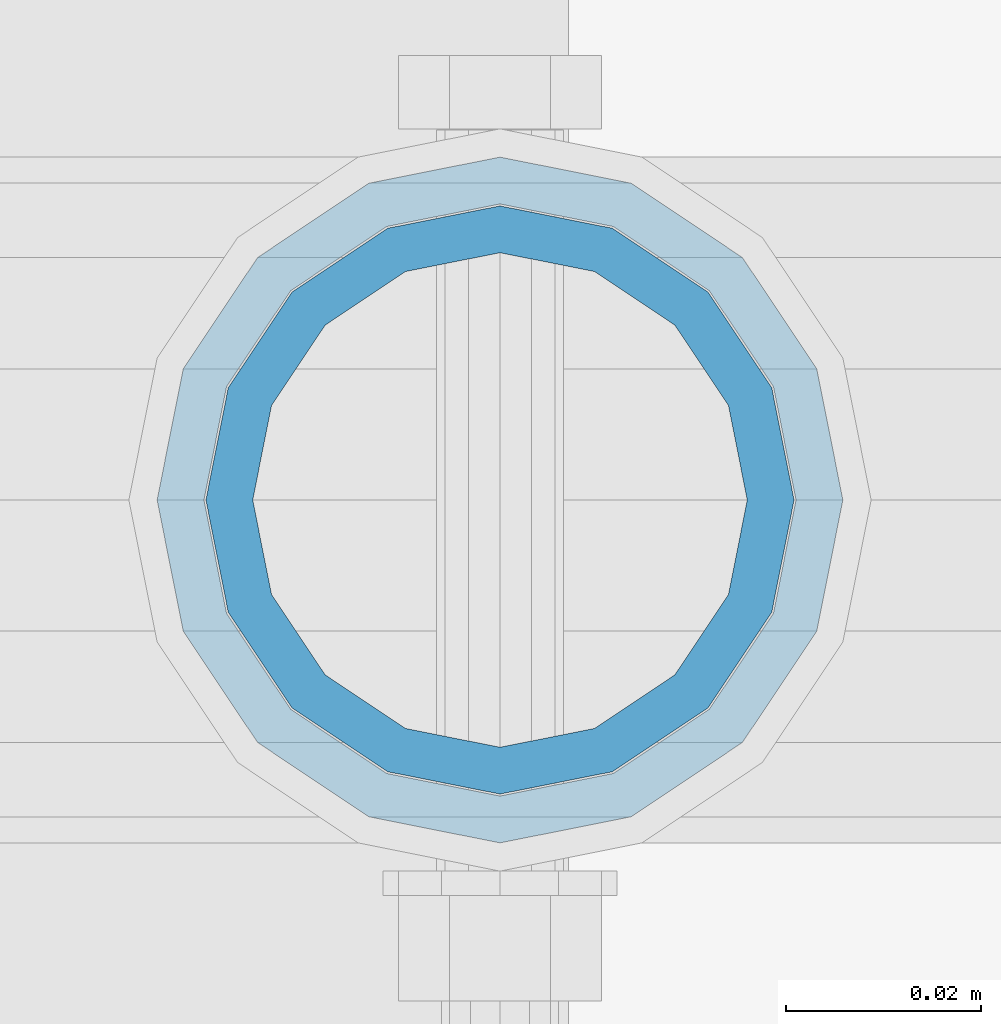
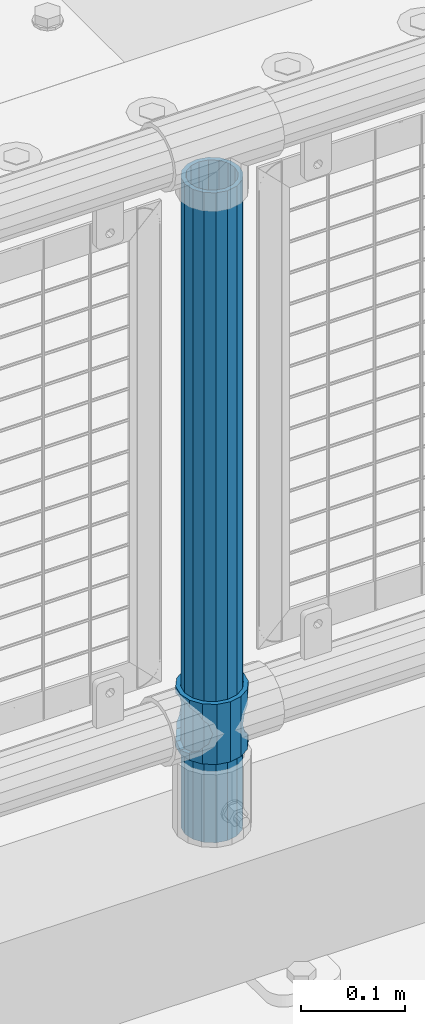
# One storey, part 82 of 240: 2 columns.
"""IFC2X3 building model written with IfcOpenShell, lengths in millimetres."""

from ifc_helpers import new_model, si_unit, frame, origin_with_axes, place, context, subcontext, project, spatial, faceted_brep, material, type_object, element, save


model = new_model("IFC2X3")

# Units and contexts
model_context = context("Model", 3, precision=1e-05, world=origin_with_axes())
body_context = subcontext(model_context, "Body", "Model", "MODEL_VIEW")
ifc_project = project(units=[si_unit("LENGTHUNIT", "METRE", prefix="MILLI"), si_unit("AREAUNIT", "SQUARE_METRE"), si_unit("VOLUMEUNIT", "CUBIC_METRE"), si_unit("MASSUNIT", "GRAM", prefix="KILO"), si_unit("TIMEUNIT", "SECOND"), si_unit("PLANEANGLEUNIT", "RADIAN"), si_unit("SOLIDANGLEUNIT", "STERADIAN"), si_unit("THERMODYNAMICTEMPERATUREUNIT", "DEGREE_CELSIUS"), si_unit("LUMINOUSINTENSITYUNIT", "LUMEN")], contexts=[model_context])

# Site, building, storey
site_placement = place(None, origin_with_axes())
site = spatial("IfcSite", under=ifc_project, at=site_placement, CompositionType="ELEMENT")
building_placement = place(site_placement, origin_with_axes())
building = spatial("IfcBuilding", under=site, at=building_placement, Name="Standard", CompositionType="ELEMENT")
storey_placement = place(building_placement, origin_with_axes())
storey = spatial("IfcBuildingStorey", under=building, at=storey_placement, Name="Undefined", CompositionType="ELEMENT", Elevation=0.0)

# Columns
ifc_material_1 = material(Name="Misc_Undefined")
column_type_1 = type_object("IfcColumnType", PredefinedType="NOTDEFINED")
column_1_placement = place(storey_placement, frame((49703.0, 34664.5, 263.02), z_axis=(-1.0, 0.0, 0.0), x_axis=(0.0, 0.0, 1.0)))
element("IfcColumn", 1, at=column_1_placement, inside=storey, type_object=column_type_1, material=ifc_material_1, context=body_context, shape_type="Brep", body=[
    faceted_brep([(56.6106908090114, 21.4606908090136, -21.4606908090136), (56.6106908090114, 21.4606908090136, -27.1226768591077), (61.9623795176703, 13.4513226476338, -32.4743655677739), (63.1897438117172, 11.6144421722784, -32.8397438117172), (63.1897438117172, 11.6144421722784, -28.0397438117143), (46.7644421722801, 28.0397438117143, -11.6144421722784), (46.7644421722801, 28.0397438117143, -20.0882031229849), (51.5310424079941, 24.8548033587067, -24.8548033587067), (35.1500000000015, 30.35, 0.0), (35.1499999999996, 30.3499999999985, -16.6306603983685), (23.5355578277192, 28.0397438117143, -11.6144421722784), (23.5355578277192, 28.0397438117143, -20.0882031229849), (13.6893091909879, 21.4606908090136, -21.4606908090136), (13.6893091909879, 21.4606908090136, -27.1226768591077), (18.7689575919921, 24.8548033587067, -24.8548033587067), (7.11025618828211, 11.6144421722784, -28.0397438117143), (7.11025618828211, 11.6144421722784, -32.8397438117172), (8.33762048232893, 13.4513226476338, -32.4743655677739), (4.79999999999961, 0.0, -30.3499999999985), (4.79999999999961, 0.0, -35.1500000000015), (7.11025618828211, -11.6144421722784, -28.0397438117143), (7.11025618828211, -11.6144421722784, -32.8397438117245), (13.6893091909879, -21.4606908090136, -21.4606908090136), (13.6893091909879, -21.4606908090136, -27.1226768591223), (8.33762048232455, -13.4513226476338, -32.4743655677739), (23.5355578277191, -28.0397438117143, -11.6144421722784), (23.5355578277191, -28.0397438117143, -20.0882031229994), (18.7689575919987, -24.8548033587067, -24.8548033587067), (35.1500000000015, -30.35, 0.0), (35.1499999999996, -30.3499999999985, -16.6306603983758), (46.7644421722801, -28.0397438117143, -11.6144421722784), (46.7644421722801, -28.0397438117143, -20.0882031229994), (56.6106908090114, -21.4606908090136, -21.4606908090136), (56.6106908090114, -21.4606908090136, -27.1226768591223), (51.5310424080006, -24.8548033587067, -24.8548033587067), (63.1897438117172, -11.6144421722784, -28.0397438117143), (63.1897438117172, -11.6144421722784, -32.8397438117245), (61.9623795176703, -13.4513226476338, -32.4743655677739), (65.4999999999997, 0.0, -30.3499999999985), (65.4999999999997, 0.0, -35.1500000000015), (0.0, -28.0397438117143, -11.6144421722784), (0.0, -30.3499999999985, 0.0), (0.0, -21.4606908090136, -21.4606908090136), (0.0, -11.6144421722784, -28.0397438117143), (0.0, 0.0, -30.3499999999985), (0.0, 11.6144421722784, -28.0397438117143), (0.0, 21.4606908090136, -21.4606908090136), (0.0, 28.0397438117143, -11.6144421722784), (0.0, 30.3499999999985, 0.0), (0.0, 28.0397438117143, 11.6144421722784), (23.5355578277192, 28.0397438117143, 11.6144421722784), (0.0, 21.4606908090136, 21.4606908090136), (13.6893091909879, 21.4606908090136, 21.4606908090136), (0.0, 11.6144421722784, 28.0397438117143), (7.11025618828211, 11.6144421722784, 28.0397438117143), (0.0, 0.0, 30.3499999999985), (4.79999999999961, 0.0, 30.3499999999985), (0.0, -11.6144421722784, 28.0397438117143), (7.11025618828205, -11.6144421722784, 28.0397438117143), (0.0, -21.4606908090136, 21.4606908090136), (13.6893091909879, -21.4606908090136, 21.4606908090136), (0.0, -28.0397438117143, 11.6144421722784), (23.5355578277191, -28.0397438117143, 11.6144421722784), (0.0, -32.4743655677739, 13.4513226476338), (0.0, -35.1500000000015, 0.0), (70.2999999999993, -35.1500000000015, 0.0), (70.2999999999993, -32.4743655677739, 13.4513226476338), (0.0, 13.4513226476338, -32.4743655677739), (0.0, 24.8548033587067, -24.8548033587067), (0.0, 0.0, -35.1500000000015), (0.0, -13.4513226476338, -32.4743655677739), (0.0, -24.8548033587067, -24.8548033587067), (0.0, -24.8548033587067, 24.8548033587067), (0.0, -13.4513226476338, 32.4743655677739), (0.0, 0.0, 35.1500000000015), (0.0, 13.4513226476338, 32.4743655677739), (0.0, 24.8548033587067, 24.8548033587067), (0.0, 32.4743655677739, 13.4513226476338), (0.0, 35.1500000000015, 0.0), (0.0, 32.4743655677739, -13.4513226476338), (0.0, -32.4743655677739, -13.4513226476338), (70.2999999999993, 32.4743655677739, 13.4513226476338), (70.2999999999993, 35.1500000000015, 0.0), (70.2999999999993, 32.4743655677739, -13.4513226476338), (70.2999999999993, 24.8548033587067, -24.8548033587067), (70.2999999999993, 13.4513226476338, -32.4743655677739), (70.2999999999993, 0.0, -35.1500000000015), (70.2999999999993, -13.4513226476338, -32.4743655677739), (70.2999999999993, -24.8548033587067, -24.8548033587067), (70.2999999999993, -32.4743655677739, -13.4513226476338), (70.2999999999993, 28.0397438117143, 11.6144421722784), (70.2999999999993, 21.4606908090136, 21.4606908090136), (56.6106908090114, 21.4606908090136, 21.4606908090136), (46.7644421722801, 28.0397438117143, 11.6144421722784), (70.2999999999993, 11.6144421722784, 28.0397438117143), (63.1897438117172, 11.6144421722784, 28.0397438117143), (70.2999999999993, 0.0, 30.3499999999985), (65.4999999999997, 0.0, 30.3499999999985), (70.2999999999993, -11.6144421722784, 28.0397438117143), (63.1897438117172, -11.6144421722784, 28.0397438117143), (70.2999999999993, -21.4606908090136, 21.4606908090136), (56.6106908090114, -21.4606908090136, 21.4606908090136), (70.2999999999993, -28.0397438117143, 11.6144421722784), (46.7644421722801, -28.0397438117143, 11.6144421722784), (70.2999999999993, -11.6144421722784, -28.0397438117143), (70.2999999999993, 0.0, -30.3499999999985), (70.2999999999993, -21.4606908090136, -21.4606908090136), (70.2999999999993, -28.0397438117143, -11.6144421722784), (70.2999999999993, -30.3499999999985, 0.0), (70.2999999999993, 24.8548033587067, 24.8548033587067), (70.2999999999993, 13.4513226476338, 32.4743655677739), (70.2999999999993, 0.0, 35.1500000000015), (70.2999999999993, -13.4513226476338, 32.4743655677739), (70.2999999999993, -24.8548033587067, 24.8548033587067), (70.2999999999993, 30.3499999999985, 0.0), (70.2999999999993, 28.0397438117143, -11.6144421722784), (70.2999999999993, 21.4606908090136, -21.4606908090136), (70.2999999999993, 11.6144421722784, -28.0397438117143), (61.9623795176742, 13.4513226476338, 32.4743655677739), (51.5310424079941, 24.8548033587067, 24.8548033587067), (56.6106908090114, 21.4606908090136, 27.1226768591077), (65.4999999999997, 0.0, 35.1500000000015), (63.1897438117172, 11.6144421722784, 32.8397438117172), (63.1897438117172, -11.6144421722784, 32.8397438117172), (61.9623795176698, -13.4513226476338, 32.4743655677739), (56.6106908090114, -21.4606908090136, 27.1226768591005), (51.5310424080006, -24.8548033587067, 24.8548033587067), (18.7689575919987, -24.8548033587067, 24.8548033587067), (46.7644421722801, -28.0397438117143, 20.0882031229994), (35.1499999999996, -30.3499999999985, 16.6306603983758), (23.5355578277191, -28.0397438117143, 20.0882031229994), (8.33762048232506, -13.4513226476338, 32.4743655677739), (13.6893091909879, -21.4606908090136, 27.1226768591005), (4.79999999999961, 0.0, 35.1500000000015), (7.11025618828205, -11.6144421722784, 32.8397438117172), (7.11025618828211, 11.6144421722784, 32.8397438117172), (8.33762048232506, 13.4513226476338, 32.4743655677739), (13.6893091909879, 21.4606908090136, 27.1226768591077), (18.7689575919856, 24.8548033587067, 24.8548033587067), (23.5355578277192, 28.0397438117143, 20.0882031229994), (35.1499999999996, 30.3499999999985, 16.6306603983758), (46.7644421722801, 28.0397438117143, 20.0882031229994)], [[[0, 1, 2, 3, 4]], [[5, 6, 7, 1, 0]], [[8, 9, 6, 5]], [[10, 11, 9, 8]], [[12, 13, 14, 11, 10]], [[15, 16, 17, 13, 12]], [[18, 19, 16, 15]], [[20, 21, 19, 18]], [[22, 23, 24, 21, 20]], [[25, 26, 27, 23, 22]], [[28, 29, 26, 25]], [[30, 31, 29, 28]], [[32, 33, 34, 31, 30]], [[35, 36, 37, 33, 32]], [[38, 39, 36, 35]], [[4, 3, 39, 38]], [[40, 41, 28, 25]], [[42, 40, 25, 22]], [[43, 42, 22, 20]], [[44, 43, 20, 18]], [[45, 44, 18, 15]], [[46, 45, 15, 12]], [[47, 46, 12, 10]], [[48, 47, 10, 8]], [[49, 48, 8, 50]], [[51, 49, 50, 52]], [[53, 51, 52, 54]], [[55, 53, 54, 56]], [[57, 55, 56, 58]], [[59, 57, 58, 60]], [[61, 59, 60, 62]], [[41, 61, 62, 28]], [[63, 64, 65, 66]], [[17, 67, 68, 14, 13]], [[19, 69, 67, 17, 16]], [[70, 69, 19, 21, 24]], [[71, 70, 24, 23, 27]], [[63, 72, 73, 74, 75, 76, 77, 78, 79, 68, 67, 69, 70, 71, 80, 64], [40, 42, 43, 44, 45, 46, 47, 48, 49, 51, 53, 55, 57, 59, 61, 41]], [[78, 77, 81, 82]], [[79, 78, 82, 83]], [[14, 68, 79, 83, 84, 7, 6, 9, 11]], [[84, 85, 2, 1, 7]], [[85, 86, 39, 3, 2]], [[37, 87, 88, 34, 33]], [[39, 86, 87, 37, 36]], [[34, 88, 89, 80, 71, 27, 26, 29, 31]], [[64, 80, 89, 65]], [[90, 91, 92, 93]], [[91, 94, 95, 92]], [[94, 96, 97, 95]], [[96, 98, 99, 97]], [[98, 100, 101, 99]], [[100, 102, 103, 101]], [[104, 105, 38, 35]], [[106, 104, 35, 32]], [[107, 106, 32, 30]], [[108, 107, 30, 28]], [[102, 108, 28, 103]], [[88, 87, 86, 85, 84, 83, 82, 81, 109, 110, 111, 112, 113, 66, 65, 89], [100, 98, 96, 94, 91, 90, 114, 115, 116, 117, 105, 104, 106, 107, 108, 102]], [[118, 110, 109, 119, 120]], [[121, 111, 110, 118, 122]], [[112, 111, 121, 123, 124]], [[113, 112, 124, 125, 126]], [[127, 72, 63, 66, 113, 126, 128, 129, 130]], [[131, 73, 72, 127, 132]], [[133, 74, 73, 131, 134]], [[75, 74, 133, 135, 136]], [[76, 75, 136, 137, 138]], [[119, 109, 81, 77, 76, 138, 139, 140, 141]], [[92, 120, 119, 141, 93]], [[95, 122, 118, 120, 92]], [[97, 121, 122, 95]], [[99, 123, 121, 97]], [[101, 125, 124, 123, 99]], [[103, 128, 126, 125, 101]], [[28, 129, 128, 103]], [[62, 130, 129, 28]], [[60, 132, 127, 130, 62]], [[58, 134, 131, 132, 60]], [[56, 133, 134, 58]], [[54, 135, 133, 56]], [[52, 137, 136, 135, 54]], [[50, 139, 138, 137, 52]], [[8, 140, 139, 50]], [[93, 141, 140, 8]], [[114, 90, 93, 8]], [[115, 114, 8, 5]], [[116, 115, 5, 0]], [[117, 116, 0, 4]], [[105, 117, 4, 38]]]),
])
ifc_material_2 = material()
column_type_2 = type_object("IfcColumnType", PredefinedType="NOTDEFINED")
column_2_placement = place(storey_placement, frame((49703.0, 34664.5, 168.02), z_axis=(-1.0, 0.0, 0.0), x_axis=(0.0, 0.0, 1.0)))
element("IfcColumn", 2, at=column_2_placement, inside=storey, type_object=column_type_2, material=ifc_material_2, context=body_context, shape_type="Brep", body=[
    faceted_brep([(0.0, -25.3499999999985, 0.0), (0.0, -23.4203461491634, 9.70102501045767), (760.0, -23.4203461491634, 9.70102501045767), (760.0, -25.3499999999985, 0.0), (0.0, -17.9251569030821, 17.9251569030821), (760.0, -17.9251569030821, 17.9251569030821), (0.0, -9.70102501045767, 23.4203461491634), (760.0, -9.70102501045767, 23.4203461491634), (0.0, 0.0, 25.3499999999985), (760.0, 0.0, 25.3499999999985), (0.0, 9.70102501045767, 23.4203461491634), (760.0, 9.70102501045767, 23.4203461491634), (0.0, 17.9251569030821, 17.9251569030821), (760.0, 17.9251569030821, 17.9251569030821), (0.0, 23.4203461491634, 9.70102501045767), (760.0, 23.4203461491634, 9.70102501045767), (0.0, 25.3499999999985, 0.0), (760.0, 25.3499999999985, 0.0), (0.0, 23.4203461491634, -9.70102501045767), (760.0, 23.4203461491634, -9.70102501045767), (0.0, 17.9251569030821, -17.9251569030821), (760.0, 17.9251569030821, -17.9251569030821), (0.0, 9.70102501045767, -23.4203461491634), (760.0, 9.70102501045767, -23.4203461491634), (0.0, 0.0, -25.3499999999985), (760.0, 0.0, -25.3499999999985), (0.0, -9.70102501045767, -23.4203461491634), (760.0, -9.70102501045767, -23.4203461491634), (0.0, -17.9251569030821, -17.9251569030821), (760.0, -17.9251569030821, -17.9251569030821), (0.0, -23.4203461491634, -9.70102501045767), (760.0, -23.4203461491634, -9.70102501045767), (0.0, -30.1500000000015, 0.0), (0.0, -27.8549679052157, -11.5379054858058), (760.0, -27.8549679052157, -11.5379054858058), (760.0, -30.1500000000015, 0.0), (0.0, -21.3192694527752, -21.3192694527752), (760.0, -21.3192694527752, -21.3192694527752), (0.0, -11.5379054858058, -27.8549679052157), (760.0, -11.5379054858058, -27.8549679052157), (0.0, 0.0, -30.1500000000015), (760.0, 0.0, -30.1500000000015), (0.0, 11.5379054858058, -27.8549679052157), (760.0, 11.5379054858058, -27.8549679052157), (0.0, 21.3192694527752, -21.3192694527752), (760.0, 21.3192694527752, -21.3192694527752), (0.0, 27.8549679052157, -11.5379054858058), (760.0, 27.8549679052157, -11.5379054858058), (0.0, 30.1500000000015, 0.0), (760.0, 30.1500000000015, 0.0), (0.0, 27.8549679052157, 11.5379054858058), (760.0, 27.8549679052157, 11.5379054858058), (0.0, 21.3192694527752, 21.3192694527752), (760.0, 21.3192694527752, 21.3192694527752), (0.0, 11.5379054858058, 27.8549679052157), (760.0, 11.5379054858058, 27.8549679052157), (0.0, 0.0, 30.1500000000015), (760.0, 0.0, 30.1500000000015), (0.0, -11.5379054858058, 27.8549679052157), (760.0, -11.5379054858058, 27.8549679052157), (0.0, -21.3192694527752, 21.3192694527752), (760.0, -21.3192694527752, 21.3192694527752), (0.0, -27.8549679052157, 11.5379054858058), (760.0, -27.8549679052157, 11.5379054858058)], [[[0, 1, 2, 3]], [[1, 4, 5, 2]], [[4, 6, 7, 5]], [[6, 8, 9, 7]], [[8, 10, 11, 9]], [[10, 12, 13, 11]], [[12, 14, 15, 13]], [[14, 16, 17, 15]], [[16, 18, 19, 17]], [[18, 20, 21, 19]], [[20, 22, 23, 21]], [[22, 24, 25, 23]], [[24, 26, 27, 25]], [[26, 28, 29, 27]], [[28, 30, 31, 29]], [[30, 0, 3, 31]], [[32, 33, 34, 35]], [[33, 36, 37, 34]], [[36, 38, 39, 37]], [[38, 40, 41, 39]], [[40, 42, 43, 41]], [[42, 44, 45, 43]], [[44, 46, 47, 45]], [[46, 48, 49, 47]], [[48, 50, 51, 49]], [[50, 52, 53, 51]], [[52, 54, 55, 53]], [[54, 56, 57, 55]], [[56, 58, 59, 57]], [[58, 60, 61, 59]], [[60, 62, 63, 61]], [[62, 32, 35, 63]], [[37, 39, 41, 43, 45, 47, 49, 51, 53, 55, 57, 59, 61, 63, 35, 34], [5, 7, 9, 11, 13, 15, 17, 19, 21, 23, 25, 27, 29, 31, 3, 2]], [[62, 60, 58, 56, 54, 52, 50, 48, 46, 44, 42, 40, 38, 36, 33, 32], [30, 28, 26, 24, 22, 20, 18, 16, 14, 12, 10, 8, 6, 4, 1, 0]]]),
])

save(model, "model.ifc")
